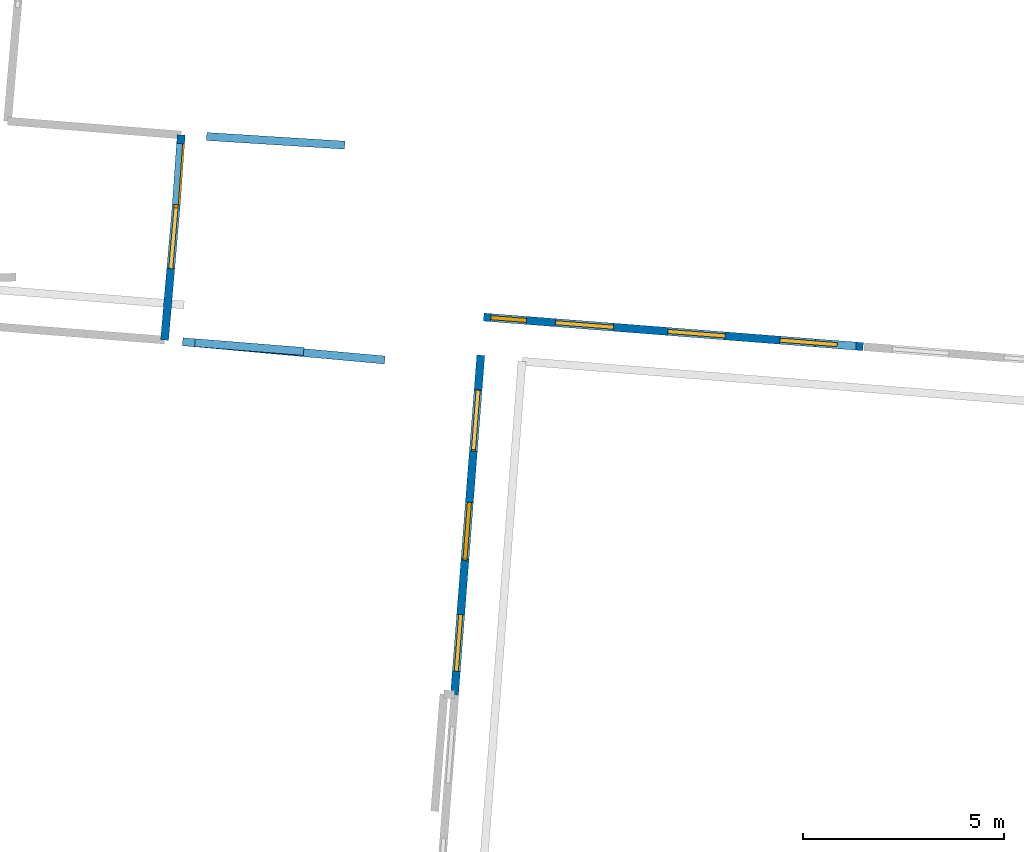
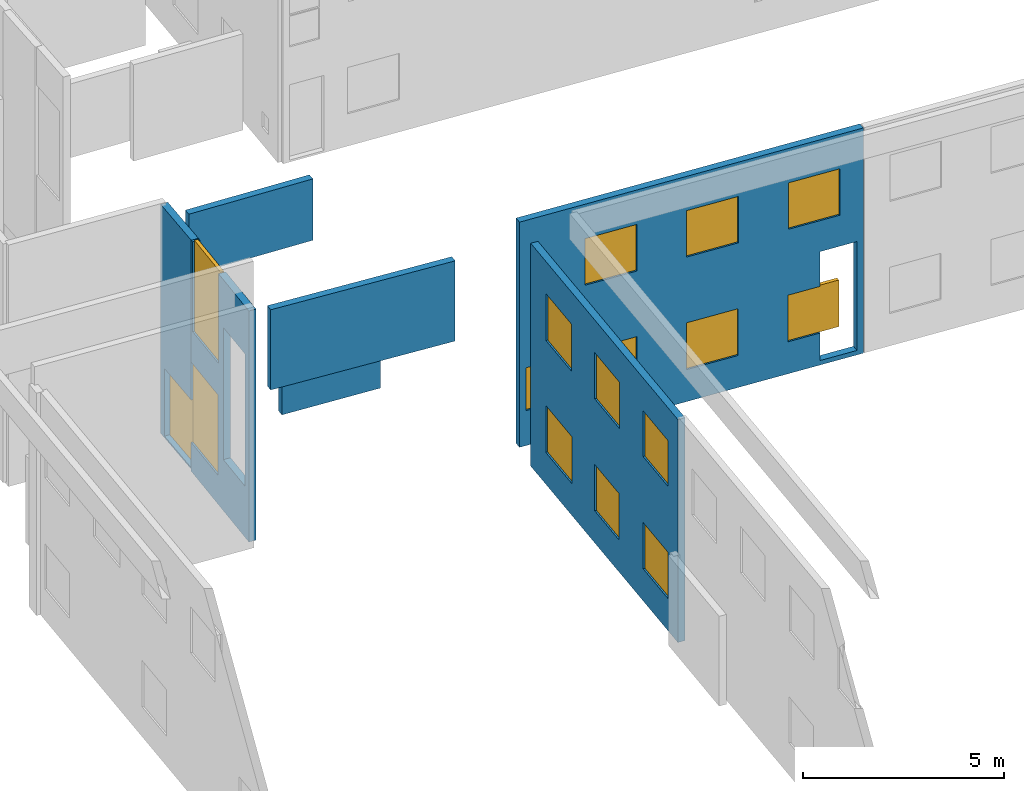
# One storey, part 7 of 27: 15 windows, 7 walls, 1 door, 18 openings.
"""IFC2X3 building model written with IfcOpenShell, lengths in metres."""

from ifc_helpers import new_model, entity, si_unit, converted_unit, derived_unit, direction, frame, frame_2d, origin, origin_2d_with_axis, place, context, subcontext, project, spatial, polyline, rectangle, outline, extrude, source, transform, mapped, material, layer, layer_set, layer_usage, type_object, type_shapes, element, fill, save


model = new_model("IFC2X3")

# Units and contexts
model_context = context("Model", 3, precision=1e-05, world=origin(), true_north=direction((0.0, 1.0)))
body_context = subcontext(model_context, "Body", "Model", "MODEL_VIEW")
ifc_project = project(units=[si_unit("LENGTHUNIT", "METRE"), si_unit("AREAUNIT", "SQUARE_METRE"), si_unit("VOLUMEUNIT", "CUBIC_METRE"), converted_unit("PLANEANGLEUNIT", "DEGREE", entity("IfcRatioMeasure", 0.0174532925199433), si_unit("PLANEANGLEUNIT", "RADIAN"), dimensions=[0, 0, 0, 0, 0, 0, 0]), si_unit("MASSUNIT", "GRAM", prefix="KILO"), derived_unit("MASSDENSITYUNIT", [(si_unit("MASSUNIT", "GRAM", prefix="KILO"), 1), (si_unit("LENGTHUNIT", "METRE"), -3)]), derived_unit("MOMENTOFINERTIAUNIT", [(si_unit("LENGTHUNIT", "METRE"), 4)]), si_unit("TIMEUNIT", "SECOND"), si_unit("FREQUENCYUNIT", "HERTZ"), si_unit("THERMODYNAMICTEMPERATUREUNIT", "DEGREE_CELSIUS"), derived_unit("THERMALTRANSMITTANCEUNIT", [(si_unit("MASSUNIT", "GRAM", prefix="KILO"), 1), (si_unit("THERMODYNAMICTEMPERATUREUNIT", "KELVIN"), -1), (si_unit("TIMEUNIT", "SECOND"), -3)]), derived_unit("VOLUMETRICFLOWRATEUNIT", [(si_unit("LENGTHUNIT", "METRE"), 3), (si_unit("TIMEUNIT", "SECOND"), -1)]), si_unit("ELECTRICCURRENTUNIT", "AMPERE"), si_unit("ELECTRICVOLTAGEUNIT", "VOLT"), si_unit("POWERUNIT", "WATT"), si_unit("FORCEUNIT", "NEWTON", prefix="KILO"), si_unit("ILLUMINANCEUNIT", "LUX"), si_unit("LUMINOUSFLUXUNIT", "LUMEN"), si_unit("LUMINOUSINTENSITYUNIT", "CANDELA"), derived_unit("USERDEFINED", [(si_unit("MASSUNIT", "GRAM", prefix="KILO"), -1), (si_unit("LENGTHUNIT", "METRE"), -2), (si_unit("TIMEUNIT", "SECOND"), 3), (si_unit("LUMINOUSFLUXUNIT", "LUMEN"), 1)]), derived_unit("LINEARVELOCITYUNIT", [(si_unit("LENGTHUNIT", "METRE"), 1), (si_unit("TIMEUNIT", "SECOND"), -1)]), si_unit("PRESSUREUNIT", "PASCAL"), derived_unit("USERDEFINED", [(si_unit("LENGTHUNIT", "METRE"), -2), (si_unit("MASSUNIT", "GRAM", prefix="KILO"), 1), (si_unit("TIMEUNIT", "SECOND"), -2)]), derived_unit("LINEARFORCEUNIT", [(si_unit("MASSUNIT", "GRAM", prefix="KILO"), 1), (si_unit("LENGTHUNIT", "METRE"), 1), (si_unit("TIMEUNIT", "SECOND"), -2), (si_unit("LENGTHUNIT", "METRE"), -1)]), derived_unit("PLANARFORCEUNIT", [(si_unit("MASSUNIT", "GRAM", prefix="KILO"), 1), (si_unit("LENGTHUNIT", "METRE"), 1), (si_unit("TIMEUNIT", "SECOND"), -2), (si_unit("LENGTHUNIT", "METRE"), -2)])], contexts=[model_context])

# Site, building, storey
placement_1 = place(None, origin())
site = spatial("IfcSite", under=ifc_project, at=placement_1, CompositionType="ELEMENT")
building = spatial("IfcBuilding", under=site, at=placement_1, CompositionType="ELEMENT")
storey_placement = place(placement_1, frame((0.0, 0.0, -61.043098449707)))
storey = spatial("IfcBuildingStorey", under=building, at=storey_placement, Name="level_-61.043098", CompositionType="ELEMENT", Elevation=-61.043098449707)

# Wall, opening, door
ifc_material_1 = material(Name="Default wall")
ifc_layer = layer(ifc_material_1, 0.2)
ifc_layer_set = layer_set([ifc_layer], Name="wall_thickness_0.2000")
ifc_layer_usage = layer_usage(ifc_layer_set, "AXIS2", "POSITIVE", -0.1)
wall_type = type_object("IfcWallType", Name="wall_thickness_0.2000", PredefinedType="STANDARD", material=ifc_layer_set)
placement_2 = place(placement_1, frame((0.0, 0.0, -60.7575225830078)))
wall_1_placement = place(placement_2, frame((-79.1526850736603, -8.72578771834073, 0.0), z_axis=(0.0, 0.0, 1.0), x_axis=(-0.0697659923199329, -0.99756338461053, 0.0)))
wall_1 = element("IfcWallStandardCase", 1, at=wall_1_placement, inside=storey, type_object=wall_type, material=ifc_layer_usage, Name="Wall:476", ObjectType="Wall", context=body_context, shape_type="SweptSolid", body=[
    extrude(outline(polyline([(1.73615057351544, -0.1), (1.73615057351544, 0.1), (0.0, 0.1), (0.0, -0.1), (1.73615057351544, -0.1)])), origin(), (0.0, 0.0, 1.0), 6.94839096069336),
])
opening_1_placement = place(wall_1_placement, frame((0.216940641888927, -0.1, 0.0471878051757812)))
opening_1 = element("IfcOpeningElement", 2, at=opening_1_placement, cuts=wall_1, Name="Opening : 1520 x 2055 : 38", ObjectType="Opening", context=body_context, shape_type="SweptSolid", body=[
    extrude(rectangle(XDim=1.52, YDim=2.055, at=frame_2d((1.0275, 0.76), x_axis=(0.0, 1.0))), frame((0.0, 0.0, 0.0), z_axis=(0.0, 1.0, 0.0), x_axis=(0.0, 0.0, 1.0)), (0.0, 0.0, 1.0), 0.2),
])
ifc_material_2 = material(Name="Door Panel")
door_style = type_object("IfcDoorStyle", Name="Door : 1520 x 2055mm", ConstructionType="NOTDEFINED", OperationType="SINGLE_SWING_RIGHT", ParameterTakesPrecedence=False, Sizeable=False, material=ifc_material_2)
shared_shape_1 = source(origin(), body_context, "Body", "SweptSolid", [
    extrude(rectangle(XDim=0.05, YDim=1.52, at=origin_2d_with_axis()), frame((0.76, 0.175, 0.0), z_axis=(0.0, 0.0, 1.0), x_axis=(0.0, 1.0, 0.0)), (0.0, 0.0, 1.0), 2.055),
])
type_shapes(door_style, [shared_shape_1])
door_placement = place(opening_1_placement, origin())
door = element("IfcDoor", 3, at=door_placement, inside=storey, type_object=door_style, Name="Door : 1520 x 2055mm : 3", ObjectType="Door : 1520 x 2055mm", OverallHeight=2.055, OverallWidth=1.52, context=body_context, shape_type="MappedRepresentation", body=[
    mapped(shared_shape_1, transform((0.0, 0.0, 0.0), scale=1.0)),
])
fill(opening_1, door)

# Walls
placement_3 = place(placement_1, frame((0.0, 0.0, -56.3052215576172)))
wall_2_placement = place(placement_3, frame((-79.1167086308441, -13.8720778619295, 0.0), z_axis=(0.0, 0.0, 1.0), x_axis=(0.995930825723696, -0.0901209763224851, 0.0)))
element("IfcWallStandardCase", 4, at=wall_2_placement, inside=storey, type_object=wall_type, material=ifc_layer_usage, Name="Wall:497", ObjectType="Wall", context=body_context, shape_type="SweptSolid", body=[
    extrude(outline(polyline([(5.05500113811745, -0.1), (5.05500113811745, 0.1), (0.0, 0.1), (0.0, -0.1), (5.05500113811745, -0.1)])), origin(), (0.0, 0.0, 1.0), 2.43331527709961),
])
placement_4 = place(placement_1, frame((0.0, 0.0, -57.1535263061523)))
wall_3_placement = place(placement_4, frame((-78.8098152160121, -13.8968240552575, 0.0), z_axis=(0.0, 0.0, 1.0), x_axis=(0.996791655170758, -0.0800399661540399, 0.0)))
element("IfcWallStandardCase", 5, at=wall_3_placement, inside=storey, type_object=wall_type, material=ifc_layer_usage, Name="Wall:513", ObjectType="Wall", context=body_context, shape_type="SweptSolid", body=[
    extrude(outline(polyline([(2.71499420696126, -0.1), (2.71499420696126, 0.1), (0.0, 0.1), (0.0, -0.1), (2.71499420696126, -0.1)])), origin(), (0.0, 0.0, 1.0), 0.871631622314453),
])

# Wall, openings, windows
placement_5 = place(placement_1, frame((0.0, 0.0, -60.8194160461426)))
wall_4_placement = place(placement_5, frame((-79.2744188761062, -10.4593208242894, 0.0), z_axis=(0.0, 0.0, 1.0), x_axis=(-0.0862396485280381, -0.996274421543462, 0.0)))
wall_4 = element("IfcWallStandardCase", 6, at=wall_4_placement, inside=storey, type_object=wall_type, material=ifc_layer_usage, Name="Wall:534", ObjectType="Wall", context=body_context, shape_type="SweptSolid", body=[
    extrude(outline(polyline([(3.38458448009172, -0.1), (3.38458448009172, 0.1), (0.0, 0.1), (0.0, -0.1), (3.38458448009172, -0.1)])), origin(), (0.0, 0.0, 1.0), 7.01028442382812),
])
opening_2_placement = place(wall_4_placement, frame((1.88850089214759, -0.1, 1.55071640014648)))
element("IfcOpeningElement", 7, at=opening_2_placement, cuts=wall_4, Name="Opening : 1275 x 4010 : 39", ObjectType="Opening", context=body_context, shape_type="SweptSolid", body=[
    extrude(rectangle(XDim=1.275, YDim=4.01, at=frame_2d((2.005, 0.6375), x_axis=(0.0, 1.0))), frame((0.0, 0.0, 0.0), z_axis=(0.0, 1.0, 0.0), x_axis=(0.0, 0.0, 1.0)), (0.0, 0.0, 1.0), 0.2),
])
opening_3_placement = place(wall_4_placement, frame((-0.00185791650529462, -0.1, 0.878635406494141)))
opening_3 = element("IfcOpeningElement", 8, at=opening_3_placement, cuts=wall_4, Name="Opening : 1590 x 2435 : 40", ObjectType="Opening", context=body_context, shape_type="SweptSolid", body=[
    extrude(rectangle(XDim=1.59, YDim=2.435, at=frame_2d((1.2175, 0.795), x_axis=(0.0, 1.0))), frame((0.0, 0.0, 0.0), z_axis=(0.0, 1.0, 0.0), x_axis=(0.0, 0.0, 1.0)), (0.0, 0.0, 1.0), 0.2),
])
opening_4_placement = place(wall_4_placement, frame((0.0803361506780836, -0.1, 4.28937530517578)))
opening_4 = element("IfcOpeningElement", 9, at=opening_4_placement, cuts=wall_4, Name="Opening : 1520 x 2755 : 41", ObjectType="Opening", context=body_context, shape_type="SweptSolid", body=[
    extrude(rectangle(XDim=1.52, YDim=2.755, at=frame_2d((1.3775, 0.76), x_axis=(0.0, 1.0))), frame((0.0, 0.0, 0.0), z_axis=(0.0, 1.0, 0.0), x_axis=(0.0, 0.0, 1.0)), (0.0, 0.0, 1.0), 0.2),
])
ifc_material_3 = material(Name="Window Default")
window_style_1 = type_object("IfcWindowStyle", Name="Window : 1590 x 2435mm", ConstructionType="NOTDEFINED", OperationType="NOTDEFINED", ParameterTakesPrecedence=False, Sizeable=False, material=ifc_material_3)
shared_shape_2 = source(origin(), body_context, "Body", "SweptSolid", [
    extrude(rectangle(XDim=0.1, YDim=1.59, at=origin_2d_with_axis()), frame((0.795, 0.1, 0.0), z_axis=(0.0, 0.0, 1.0), x_axis=(0.0, 1.0, 0.0)), (0.0, 0.0, 1.0), 2.435),
])
type_shapes(window_style_1, [shared_shape_2])
window_1_placement = place(opening_3_placement, origin())
window_1 = element("IfcWindow", 10, at=window_1_placement, inside=storey, type_object=window_style_1, Name="Window : 1590 x 2435mm : 33", ObjectType="Window : 1590 x 2435mm", OverallHeight=2.435, OverallWidth=1.59, context=body_context, shape_type="MappedRepresentation", body=[
    mapped(shared_shape_2, transform((0.0, 0.0, 0.0), scale=1.0)),
])
fill(opening_3, window_1)
window_style_2 = type_object("IfcWindowStyle", Name="Window : 1520 x 2755mm", ConstructionType="NOTDEFINED", OperationType="NOTDEFINED", ParameterTakesPrecedence=False, Sizeable=False, material=ifc_material_3)
shared_shape_3 = source(origin(), body_context, "Body", "SweptSolid", [
    extrude(rectangle(XDim=0.1, YDim=1.52, at=origin_2d_with_axis()), frame((0.76, 0.1, 0.0), z_axis=(0.0, 0.0, 1.0), x_axis=(0.0, 1.0, 0.0)), (0.0, 0.0, 1.0), 2.755),
])
type_shapes(window_style_2, [shared_shape_3])
window_2_placement = place(opening_4_placement, origin())
window_2 = element("IfcWindow", 11, at=window_2_placement, inside=storey, type_object=window_style_2, Name="Window : 1520 x 2755mm : 34", ObjectType="Window : 1520 x 2755mm", OverallHeight=2.755, OverallWidth=1.52, context=body_context, shape_type="MappedRepresentation", body=[
    mapped(shared_shape_3, transform((0.0, 0.0, 0.0), scale=1.0)),
])
fill(opening_4, window_2)

wall_5_placement = place(storey_placement, frame((-71.6939242402664, -14.2091124767118, 0.0), z_axis=(0.0, 0.0, 1.0), x_axis=(-0.0772450812741805, -0.997012135040966, 0.0)))
wall_5 = element("IfcWallStandardCase", 12, at=wall_5_placement, inside=storey, type_object=wall_type, material=ifc_layer_usage, Name="Wall:715", ObjectType="Wall", context=body_context, shape_type="SweptSolid", body=[
    extrude(outline(polyline([(8.47415500371784, -0.1), (8.47415500371784, 0.1), (0.0, 0.1), (0.0, -0.1), (8.47415500371784, -0.1)])), origin(), (0.0, 0.0, 1.0), 6.76219177246094),
])
opening_5_placement = place(wall_5_placement, frame((0.874999303517512, -0.1, 4.36384582519531)))
opening_5 = element("IfcOpeningElement", 13, at=opening_5_placement, cuts=wall_5, Name="Opening : 1475 x 1425 : 72", ObjectType="Opening", context=body_context, shape_type="SweptSolid", body=[
    extrude(rectangle(XDim=1.475, YDim=1.425, at=frame_2d((0.7125, 0.7375), x_axis=(0.0, 1.0))), frame((0.0, 0.0, 0.0), z_axis=(0.0, 1.0, 0.0), x_axis=(0.0, 0.0, 1.0)), (0.0, 0.0, 1.0), 0.2),
])
opening_6_placement = place(wall_5_placement, frame((3.68500023960541, -0.1, 4.36884689331055)))
opening_6 = element("IfcOpeningElement", 14, at=opening_6_placement, cuts=wall_5, Name="Opening : 1440 x 1405 : 73", ObjectType="Opening", context=body_context, shape_type="SweptSolid", body=[
    extrude(rectangle(XDim=1.44, YDim=1.405, at=frame_2d((0.7025, 0.72), x_axis=(0.0, 1.0))), frame((0.0, 0.0, 0.0), z_axis=(0.0, 1.0, 0.0), x_axis=(0.0, 0.0, 1.0)), (0.0, 0.0, 1.0), 0.2),
])
opening_7_placement = place(wall_5_placement, frame((6.46999941403732, -0.1, 4.37884902954102)))
opening_7 = element("IfcOpeningElement", 15, at=opening_7_placement, cuts=wall_5, Name="Opening : 1420 x 1390 : 74", ObjectType="Opening", context=body_context, shape_type="SweptSolid", body=[
    extrude(rectangle(XDim=1.42, YDim=1.39, at=frame_2d((0.695, 0.71), x_axis=(0.0, 1.0))), frame((0.0, 0.0, 0.0), z_axis=(0.0, 1.0, 0.0), x_axis=(0.0, 0.0, 1.0)), (0.0, 0.0, 1.0), 0.2),
])
opening_8_placement = place(wall_5_placement, frame((0.869999285947952, -0.1, 0.963848114013672)))
opening_8 = element("IfcOpeningElement", 16, at=opening_8_placement, cuts=wall_5, Name="Opening : 1520 x 1425 : 75", ObjectType="Opening", context=body_context, shape_type="SweptSolid", body=[
    extrude(rectangle(XDim=1.52, YDim=1.425, at=frame_2d((0.7125, 0.76), x_axis=(0.0, 1.0))), frame((0.0, 0.0, 0.0), z_axis=(0.0, 1.0, 0.0), x_axis=(0.0, 0.0, 1.0)), (0.0, 0.0, 1.0), 0.2),
])
opening_9_placement = place(wall_5_placement, frame((3.67499889214976, -0.1, 0.968849182128906)))
opening_9 = element("IfcOpeningElement", 17, at=opening_9_placement, cuts=wall_5, Name="Opening : 1415 x 1410 : 76", ObjectType="Opening", context=body_context, shape_type="SweptSolid", body=[
    extrude(rectangle(XDim=1.415, YDim=1.41, at=frame_2d((0.705, 0.7075), x_axis=(0.0, 1.0))), frame((0.0, 0.0, 0.0), z_axis=(0.0, 1.0, 0.0), x_axis=(0.0, 0.0, 1.0)), (0.0, 0.0, 1.0), 0.2),
])
opening_10_placement = place(wall_5_placement, frame((6.47500038243175, -0.1, 0.973846435546875)))
opening_10 = element("IfcOpeningElement", 18, at=opening_10_placement, cuts=wall_5, Name="Opening : 1415 x 1405 : 77", ObjectType="Opening", context=body_context, shape_type="SweptSolid", body=[
    extrude(rectangle(XDim=1.415, YDim=1.405, at=frame_2d((0.7025, 0.7075), x_axis=(0.0, 1.0))), frame((0.0, 0.0, 0.0), z_axis=(0.0, 1.0, 0.0), x_axis=(0.0, 0.0, 1.0)), (0.0, 0.0, 1.0), 0.2),
])
window_style_3 = type_object("IfcWindowStyle", Name="Window : 1420 x 1390mm", ConstructionType="NOTDEFINED", OperationType="NOTDEFINED", ParameterTakesPrecedence=False, Sizeable=False, material=ifc_material_3)
shared_shape_4 = source(origin(), body_context, "Body", "SweptSolid", [
    extrude(rectangle(XDim=0.1, YDim=1.42, at=origin_2d_with_axis()), frame((0.71, 0.1, 0.0), z_axis=(0.0, 0.0, 1.0), x_axis=(0.0, 1.0, 0.0)), (0.0, 0.0, 1.0), 1.39),
])
type_shapes(window_style_3, [shared_shape_4])
window_3_placement = place(opening_7_placement, origin())
window_3 = element("IfcWindow", 19, at=window_3_placement, inside=storey, type_object=window_style_3, Name="Window : 1420 x 1390mm : 66", ObjectType="Window : 1420 x 1390mm", OverallHeight=1.39, OverallWidth=1.42, context=body_context, shape_type="MappedRepresentation", body=[
    mapped(shared_shape_4, transform((0.0, 0.0, 0.0), scale=1.0)),
])
fill(opening_7, window_3)
window_style_4 = type_object("IfcWindowStyle", Name="Window : 1415 x 1405mm", ConstructionType="NOTDEFINED", OperationType="NOTDEFINED", ParameterTakesPrecedence=False, Sizeable=False, material=ifc_material_3)
shared_shape_5 = source(origin(), body_context, "Body", "SweptSolid", [
    extrude(rectangle(XDim=0.1, YDim=1.415, at=origin_2d_with_axis()), frame((0.7075, 0.1, 0.0), z_axis=(0.0, 0.0, 1.0), x_axis=(0.0, 1.0, 0.0)), (0.0, 0.0, 1.0), 1.405),
])
type_shapes(window_style_4, [shared_shape_5])
window_4_placement = place(opening_10_placement, origin())
window_4 = element("IfcWindow", 20, at=window_4_placement, inside=storey, type_object=window_style_4, Name="Window : 1415 x 1405mm : 69", ObjectType="Window : 1415 x 1405mm", OverallHeight=1.405, OverallWidth=1.415, context=body_context, shape_type="MappedRepresentation", body=[
    mapped(shared_shape_5, transform((0.0, 0.0, 0.0), scale=1.0)),
])
fill(opening_10, window_4)
window_style_5 = type_object("IfcWindowStyle", Name="Window : 1475 x 1425mm", ConstructionType="NOTDEFINED", OperationType="NOTDEFINED", ParameterTakesPrecedence=False, Sizeable=False, material=ifc_material_3)
shared_shape_6 = source(origin(), body_context, "Body", "SweptSolid", [
    extrude(rectangle(XDim=0.1, YDim=1.475, at=origin_2d_with_axis()), frame((0.7375, 0.1, 0.0), z_axis=(0.0, 0.0, 1.0), x_axis=(0.0, 1.0, 0.0)), (0.0, 0.0, 1.0), 1.425),
])
type_shapes(window_style_5, [shared_shape_6])
window_5_placement = place(opening_5_placement, origin())
window_5 = element("IfcWindow", 21, at=window_5_placement, inside=storey, type_object=window_style_5, Name="Window : 1475 x 1425mm : 64", ObjectType="Window : 1475 x 1425mm", OverallHeight=1.425, OverallWidth=1.475, context=body_context, shape_type="MappedRepresentation", body=[
    mapped(shared_shape_6, transform((0.0, 0.0, 0.0), scale=1.0)),
])
fill(opening_5, window_5)
window_style_6 = type_object("IfcWindowStyle", Name="Window : 1440 x 1405mm", ConstructionType="NOTDEFINED", OperationType="NOTDEFINED", ParameterTakesPrecedence=False, Sizeable=False, material=ifc_material_3)
shared_shape_7 = source(origin(), body_context, "Body", "SweptSolid", [
    extrude(rectangle(XDim=0.1, YDim=1.44, at=origin_2d_with_axis()), frame((0.72, 0.1, 0.0), z_axis=(0.0, 0.0, 1.0), x_axis=(0.0, 1.0, 0.0)), (0.0, 0.0, 1.0), 1.405),
])
type_shapes(window_style_6, [shared_shape_7])
window_6_placement = place(opening_6_placement, origin())
window_6 = element("IfcWindow", 22, at=window_6_placement, inside=storey, type_object=window_style_6, Name="Window : 1440 x 1405mm : 65", ObjectType="Window : 1440 x 1405mm", OverallHeight=1.405, OverallWidth=1.44, context=body_context, shape_type="MappedRepresentation", body=[
    mapped(shared_shape_7, transform((0.0, 0.0, 0.0), scale=1.0)),
])
fill(opening_6, window_6)
window_style_7 = type_object("IfcWindowStyle", Name="Window : 1520 x 1425mm", ConstructionType="NOTDEFINED", OperationType="NOTDEFINED", ParameterTakesPrecedence=False, Sizeable=False, material=ifc_material_3)
shared_shape_8 = source(origin(), body_context, "Body", "SweptSolid", [
    extrude(rectangle(XDim=0.1, YDim=1.52, at=origin_2d_with_axis()), frame((0.76, 0.1, 0.0), z_axis=(0.0, 0.0, 1.0), x_axis=(0.0, 1.0, 0.0)), (0.0, 0.0, 1.0), 1.425),
])
type_shapes(window_style_7, [shared_shape_8])
window_7_placement = place(opening_8_placement, origin())
window_7 = element("IfcWindow", 23, at=window_7_placement, inside=storey, type_object=window_style_7, Name="Window : 1520 x 1425mm : 67", ObjectType="Window : 1520 x 1425mm", OverallHeight=1.425, OverallWidth=1.52, context=body_context, shape_type="MappedRepresentation", body=[
    mapped(shared_shape_8, transform((0.0, 0.0, 0.0), scale=1.0)),
])
fill(opening_8, window_7)
window_style_8 = type_object("IfcWindowStyle", Name="Window : 1415 x 1410mm", ConstructionType="NOTDEFINED", OperationType="NOTDEFINED", ParameterTakesPrecedence=False, Sizeable=False, material=ifc_material_3)
shared_shape_9 = source(origin(), body_context, "Body", "SweptSolid", [
    extrude(rectangle(XDim=0.1, YDim=1.415, at=origin_2d_with_axis()), frame((0.7075, 0.1, 0.0), z_axis=(0.0, 0.0, 1.0), x_axis=(0.0, 1.0, 0.0)), (0.0, 0.0, 1.0), 1.41),
])
type_shapes(window_style_8, [shared_shape_9])
window_8_placement = place(opening_9_placement, origin())
window_8 = element("IfcWindow", 24, at=window_8_placement, inside=storey, type_object=window_style_8, Name="Window : 1415 x 1410mm : 68", ObjectType="Window : 1415 x 1410mm", OverallHeight=1.41, OverallWidth=1.415, context=body_context, shape_type="MappedRepresentation", body=[
    mapped(shared_shape_9, transform((0.0, 0.0, 0.0), scale=1.0)),
])
fill(opening_9, window_8)

wall_6_placement = place(storey_placement, frame((-71.6220403725772, -13.2587802082675, 0.0), z_axis=(0.0, 0.0, 1.0), x_axis=(0.996973837661527, -0.0777378094523296, 0.0)))
wall_6 = element("IfcWallStandardCase", 25, at=wall_6_placement, inside=storey, type_object=wall_type, material=ifc_layer_usage, Name="Wall:1115", ObjectType="Wall", context=body_context, shape_type="SweptSolid", body=[
    extrude(outline(polyline([(9.47449502946782, -0.1), (9.47449502946782, 0.1), (0.0, 0.1), (0.0, -0.1), (9.47449502946782, -0.1)])), origin(), (0.0, 0.0, 1.0), 6.83392333984375),
])
opening_11_placement = place(wall_6_placement, frame((8.28202838494219, -0.1, 0.13555908203125)))
element("IfcOpeningElement", 26, at=opening_11_placement, cuts=wall_6, Name="Opening : 1015 x 3305 : 136", ObjectType="Opening", context=body_context, shape_type="SweptSolid", body=[
    extrude(rectangle(XDim=1.015, YDim=3.305, at=frame_2d((1.6525, 0.5075), x_axis=(0.0, 1.0))), frame((0.0, 0.0, 0.0), z_axis=(0.0, 1.0, 0.0), x_axis=(0.0, 0.0, 1.0)), (0.0, 0.0, 1.0), 0.2),
])
opening_12_placement = place(wall_6_placement, frame((4.59949779055417, -0.1, 4.38547134399414)))
opening_12 = element("IfcOpeningElement", 27, at=opening_12_placement, cuts=wall_6, Name="Opening : 1435 x 1410 : 137", ObjectType="Opening", context=body_context, shape_type="SweptSolid", body=[
    extrude(rectangle(XDim=1.435, YDim=1.41, at=frame_2d((0.705, 0.7175), x_axis=(0.0, 1.0))), frame((0.0, 0.0, 0.0), z_axis=(0.0, 1.0, 0.0), x_axis=(0.0, 0.0, 1.0)), (0.0, 0.0, 1.0), 0.2),
])
opening_13_placement = place(wall_6_placement, frame((1.79949007637169, -0.1, 4.37546920776367)))
opening_13 = element("IfcOpeningElement", 28, at=opening_13_placement, cuts=wall_6, Name="Opening : 1440 x 1415 : 138", ObjectType="Opening", context=body_context, shape_type="SweptSolid", body=[
    extrude(rectangle(XDim=1.44, YDim=1.415, at=frame_2d((0.7075, 0.72), x_axis=(0.0, 1.0))), frame((0.0, 0.0, 0.0), z_axis=(0.0, 1.0, 0.0), x_axis=(0.0, 0.0, 1.0)), (0.0, 0.0, 1.0), 0.2),
])
opening_14_placement = place(wall_6_placement, frame((7.40449491617453, -0.1, 4.38047027587891)))
opening_14 = element("IfcOpeningElement", 29, at=opening_14_placement, cuts=wall_6, Name="Opening : 1425 x 1410 : 139", ObjectType="Opening", context=body_context, shape_type="SweptSolid", body=[
    extrude(rectangle(XDim=1.425, YDim=1.41, at=frame_2d((0.705, 0.7125), x_axis=(0.0, 1.0))), frame((0.0, 0.0, 0.0), z_axis=(0.0, 1.0, 0.0), x_axis=(0.0, 0.0, 1.0)), (0.0, 0.0, 1.0), 0.2),
])
opening_15_placement = place(wall_6_placement, frame((1.78949581847279, -0.1, 0.970470428466797)))
opening_15 = element("IfcOpeningElement", 30, at=opening_15_placement, cuts=wall_6, Name="Opening : 1445 x 1415 : 140", ObjectType="Opening", context=body_context, shape_type="SweptSolid", body=[
    extrude(rectangle(XDim=1.445, YDim=1.415, at=frame_2d((0.7075, 0.7225), x_axis=(0.0, 1.0))), frame((0.0, 0.0, 0.0), z_axis=(0.0, 1.0, 0.0), x_axis=(0.0, 0.0, 1.0)), (0.0, 0.0, 1.0), 0.2),
])
opening_16_placement = place(wall_6_placement, frame((4.59949779055417, -0.1, 0.970470428466797)))
opening_16 = element("IfcOpeningElement", 31, at=opening_16_placement, cuts=wall_6, Name="Opening : 1425 x 1420 : 141", ObjectType="Opening", context=body_context, shape_type="SweptSolid", body=[
    extrude(rectangle(XDim=1.425, YDim=1.42, at=frame_2d((0.71, 0.7125), x_axis=(0.0, 1.0))), frame((0.0, 0.0, 0.0), z_axis=(0.0, 1.0, 0.0), x_axis=(0.0, 0.0, 1.0)), (0.0, 0.0, 1.0), 0.2),
])
opening_17_placement = place(wall_6_placement, frame((7.39449305196889, -0.1, 0.970470428466797)))
opening_17 = element("IfcOpeningElement", 32, at=opening_17_placement, cuts=wall_6, Name="Opening : 1425 x 1415 : 142", ObjectType="Opening", context=body_context, shape_type="SweptSolid", body=[
    extrude(rectangle(XDim=1.425, YDim=1.415, at=frame_2d((0.7075, 0.7125), x_axis=(0.0, 1.0))), frame((0.0, 0.0, 0.0), z_axis=(0.0, 1.0, 0.0), x_axis=(0.0, 0.0, 1.0)), (0.0, 0.0, 1.0), 0.2),
])
opening_18_placement = place(wall_6_placement, frame((0.179490622187191, -0.1, 1.06047058105469)))
opening_18 = element("IfcOpeningElement", 33, at=opening_18_placement, cuts=wall_6, Name="Opening : 885 x 1300 : 143", ObjectType="Opening", context=body_context, shape_type="SweptSolid", body=[
    extrude(rectangle(XDim=0.885, YDim=1.3, at=frame_2d((0.65, 0.4425), x_axis=(0.0, 1.0))), frame((0.0, 0.0, 0.0), z_axis=(0.0, 1.0, 0.0), x_axis=(0.0, 0.0, 1.0)), (0.0, 0.0, 1.0), 0.2),
])
window_style_9 = type_object("IfcWindowStyle", Name="Window : 1435 x 1410mm", ConstructionType="NOTDEFINED", OperationType="NOTDEFINED", ParameterTakesPrecedence=False, Sizeable=False, material=ifc_material_3)
shared_shape_10 = source(origin(), body_context, "Body", "SweptSolid", [
    extrude(rectangle(XDim=0.1, YDim=1.435, at=origin_2d_with_axis()), frame((0.7175, 0.1, 0.0), z_axis=(0.0, 0.0, 1.0), x_axis=(0.0, 1.0, 0.0)), (0.0, 0.0, 1.0), 1.41),
])
type_shapes(window_style_9, [shared_shape_10])
window_9_placement = place(opening_12_placement, origin())
window_9 = element("IfcWindow", 34, at=window_9_placement, inside=storey, type_object=window_style_9, Name="Window : 1435 x 1410mm : 123", ObjectType="Window : 1435 x 1410mm", OverallHeight=1.41, OverallWidth=1.435, context=body_context, shape_type="MappedRepresentation", body=[
    mapped(shared_shape_10, transform((0.0, 0.0, 0.0), scale=1.0)),
])
fill(opening_12, window_9)
window_style_10 = type_object("IfcWindowStyle", Name="Window : 1440 x 1415mm", ConstructionType="NOTDEFINED", OperationType="NOTDEFINED", ParameterTakesPrecedence=False, Sizeable=False, material=ifc_material_3)
shared_shape_11 = source(origin(), body_context, "Body", "SweptSolid", [
    extrude(rectangle(XDim=0.1, YDim=1.44, at=origin_2d_with_axis()), frame((0.72, 0.1, 0.0), z_axis=(0.0, 0.0, 1.0), x_axis=(0.0, 1.0, 0.0)), (0.0, 0.0, 1.0), 1.415),
])
type_shapes(window_style_10, [shared_shape_11])
window_10_placement = place(opening_13_placement, origin())
window_10 = element("IfcWindow", 35, at=window_10_placement, inside=storey, type_object=window_style_10, Name="Window : 1440 x 1415mm : 124", ObjectType="Window : 1440 x 1415mm", OverallHeight=1.415, OverallWidth=1.44, context=body_context, shape_type="MappedRepresentation", body=[
    mapped(shared_shape_11, transform((0.0, 0.0, 0.0), scale=1.0)),
])
fill(opening_13, window_10)
window_style_11 = type_object("IfcWindowStyle", Name="Window : 1425 x 1410mm", ConstructionType="NOTDEFINED", OperationType="NOTDEFINED", ParameterTakesPrecedence=False, Sizeable=False, material=ifc_material_3)
shared_shape_12 = source(origin(), body_context, "Body", "SweptSolid", [
    extrude(rectangle(XDim=0.1, YDim=1.425, at=origin_2d_with_axis()), frame((0.7125, 0.1, 0.0), z_axis=(0.0, 0.0, 1.0), x_axis=(0.0, 1.0, 0.0)), (0.0, 0.0, 1.0), 1.41),
])
type_shapes(window_style_11, [shared_shape_12])
window_11_placement = place(opening_14_placement, origin())
window_11 = element("IfcWindow", 36, at=window_11_placement, inside=storey, type_object=window_style_11, Name="Window : 1425 x 1410mm : 125", ObjectType="Window : 1425 x 1410mm", OverallHeight=1.41, OverallWidth=1.425, context=body_context, shape_type="MappedRepresentation", body=[
    mapped(shared_shape_12, transform((0.0, 0.0, 0.0), scale=1.0)),
])
fill(opening_14, window_11)
window_style_12 = type_object("IfcWindowStyle", Name="Window : 1445 x 1415mm", ConstructionType="NOTDEFINED", OperationType="NOTDEFINED", ParameterTakesPrecedence=False, Sizeable=False, material=ifc_material_3)
shared_shape_13 = source(origin(), body_context, "Body", "SweptSolid", [
    extrude(rectangle(XDim=0.1, YDim=1.445, at=origin_2d_with_axis()), frame((0.7225, 0.1, 0.0), z_axis=(0.0, 0.0, 1.0), x_axis=(0.0, 1.0, 0.0)), (0.0, 0.0, 1.0), 1.415),
])
type_shapes(window_style_12, [shared_shape_13])
window_12_placement = place(opening_15_placement, origin())
window_12 = element("IfcWindow", 37, at=window_12_placement, inside=storey, type_object=window_style_12, Name="Window : 1445 x 1415mm : 126", ObjectType="Window : 1445 x 1415mm", OverallHeight=1.415, OverallWidth=1.445, context=body_context, shape_type="MappedRepresentation", body=[
    mapped(shared_shape_13, transform((0.0, 0.0, 0.0), scale=1.0)),
])
fill(opening_15, window_12)
window_style_13 = type_object("IfcWindowStyle", Name="Window : 1425 x 1420mm", ConstructionType="NOTDEFINED", OperationType="NOTDEFINED", ParameterTakesPrecedence=False, Sizeable=False, material=ifc_material_3)
shared_shape_14 = source(origin(), body_context, "Body", "SweptSolid", [
    extrude(rectangle(XDim=0.1, YDim=1.425, at=origin_2d_with_axis()), frame((0.7125, 0.1, 0.0), z_axis=(0.0, 0.0, 1.0), x_axis=(0.0, 1.0, 0.0)), (0.0, 0.0, 1.0), 1.42),
])
type_shapes(window_style_13, [shared_shape_14])
window_13_placement = place(opening_16_placement, origin())
window_13 = element("IfcWindow", 38, at=window_13_placement, inside=storey, type_object=window_style_13, Name="Window : 1425 x 1420mm : 127", ObjectType="Window : 1425 x 1420mm", OverallHeight=1.42, OverallWidth=1.425, context=body_context, shape_type="MappedRepresentation", body=[
    mapped(shared_shape_14, transform((0.0, 0.0, 0.0), scale=1.0)),
])
fill(opening_16, window_13)
window_style_14 = type_object("IfcWindowStyle", Name="Window : 1425 x 1415mm", ConstructionType="NOTDEFINED", OperationType="NOTDEFINED", ParameterTakesPrecedence=False, Sizeable=False, material=ifc_material_3)
shared_shape_15 = source(origin(), body_context, "Body", "SweptSolid", [
    extrude(rectangle(XDim=0.1, YDim=1.425, at=origin_2d_with_axis()), frame((0.7125, 0.1, 0.0), z_axis=(0.0, 0.0, 1.0), x_axis=(0.0, 1.0, 0.0)), (0.0, 0.0, 1.0), 1.415),
])
type_shapes(window_style_14, [shared_shape_15])
window_14_placement = place(opening_17_placement, origin())
window_14 = element("IfcWindow", 39, at=window_14_placement, inside=storey, type_object=window_style_14, Name="Window : 1425 x 1415mm : 128", ObjectType="Window : 1425 x 1415mm", OverallHeight=1.415, OverallWidth=1.425, context=body_context, shape_type="MappedRepresentation", body=[
    mapped(shared_shape_15, transform((0.0, 0.0, 0.0), scale=1.0)),
])
fill(opening_17, window_14)
window_style_15 = type_object("IfcWindowStyle", Name="Window : 885 x 1300mm", ConstructionType="NOTDEFINED", OperationType="NOTDEFINED", ParameterTakesPrecedence=False, Sizeable=False, material=ifc_material_3)
shared_shape_16 = source(origin(), body_context, "Body", "SweptSolid", [
    extrude(rectangle(XDim=0.1, YDim=0.885, at=origin_2d_with_axis()), frame((0.4425, 0.1, 0.0), z_axis=(0.0, 0.0, 1.0), x_axis=(0.0, 1.0, 0.0)), (0.0, 0.0, 1.0), 1.3),
])
type_shapes(window_style_15, [shared_shape_16])
window_15_placement = place(opening_18_placement, origin())
window_15 = element("IfcWindow", 40, at=window_15_placement, inside=storey, type_object=window_style_15, Name="Window : 885 x 1300mm : 129", ObjectType="Window : 885 x 1300mm", OverallHeight=1.3, OverallWidth=0.885, context=body_context, shape_type="MappedRepresentation", body=[
    mapped(shared_shape_16, transform((0.0, 0.0, 0.0), scale=1.0)),
])
fill(opening_18, window_15)

# Wall
placement_6 = place(placement_1, frame((0.0, 0.0, -56.1419982910156)))
wall_7_placement = place(placement_6, frame((-78.5184626119309, -8.76335748151075, 0.0), z_axis=(0.0, 0.0, 1.0), x_axis=(0.998045592269262, -0.0624899652096097, 0.0)))
element("IfcWallStandardCase", 41, at=wall_7_placement, inside=storey, type_object=wall_type, material=ifc_layer_usage, Name="Wall:1714", ObjectType="Wall", context=body_context, shape_type="SweptSolid", body=[
    extrude(outline(polyline([(3.44499586600601, -0.1), (3.44499586600601, 0.1), (0.0, 0.1), (0.0, -0.1), (3.44499586600601, -0.1)])), origin(), (0.0, 0.0, 1.0), 1.86109161376953),
])

save(model, "model.ifc")
